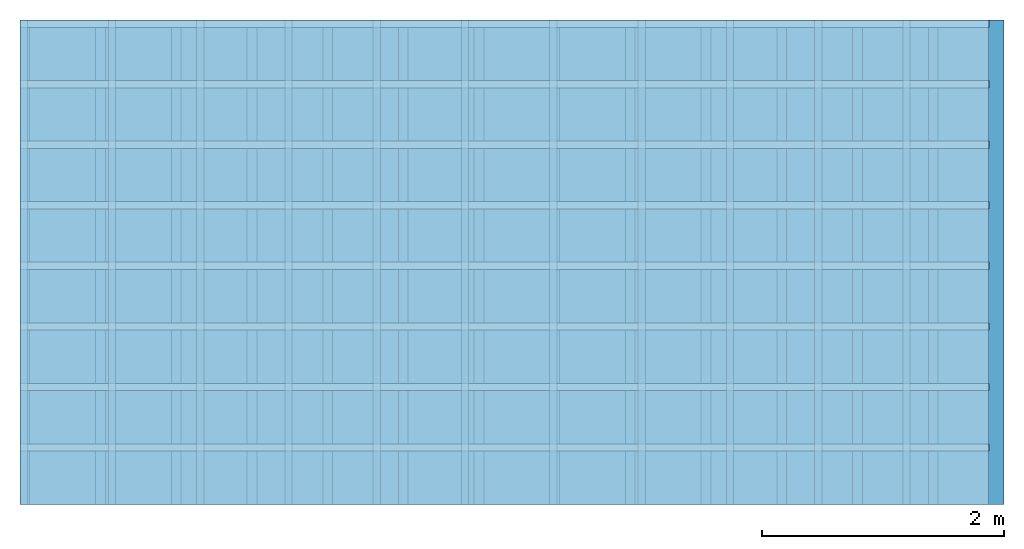
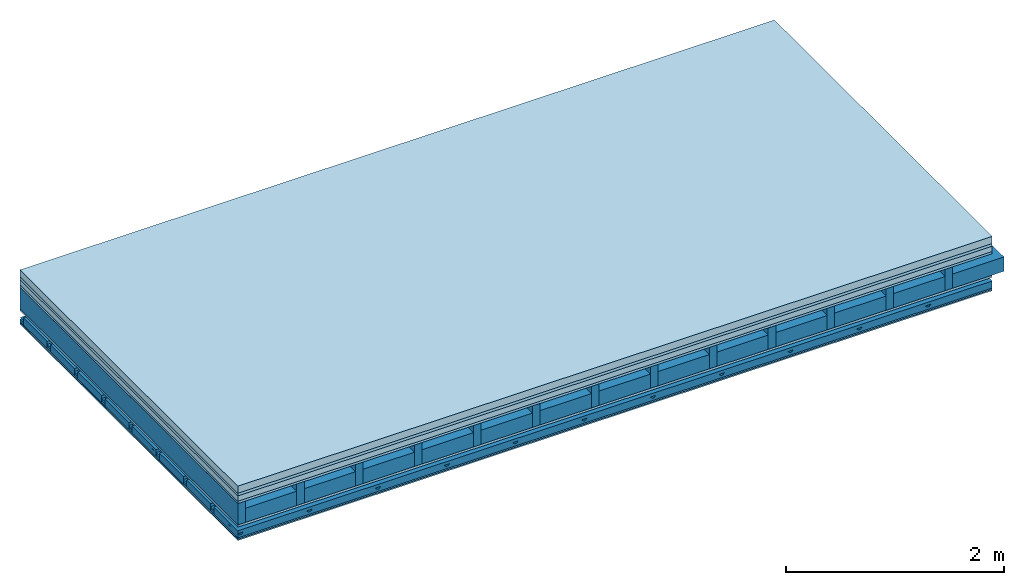
# One storey: 7 plates, 5 members, 1 element without a shape of its own.
"""IFC4 building model written with IfcOpenShell, lengths in metres."""

from ifc_helpers import new_model, si_unit, derived_unit, direction, frame, frame_2d, origin, origin_with_axes, place, context, project, spatial, polyline, rectangle, outline, extrude, material, layer, layer_set, type_object, element, aggregate, save


model = new_model("IFC4")

# Units and contexts
plan_context = context("Plan", 3, precision=1e-05, world=origin(), true_north=direction((0.0, 1.0)))
model_context = context("Model", 3, precision=1e-05, world=origin(), true_north=direction((0.0, 1.0)))
ifc_project = project(units=[si_unit("LENGTHUNIT", "METRE"), derived_unit("SOUNDPRESSUREUNIT", [(si_unit("PRESSUREUNIT", "PASCAL", prefix="MICRO"), 0)]), si_unit("ENERGYUNIT", "JOULE", prefix="MEGA"), si_unit("MASSUNIT", "GRAM", prefix="KILO"), derived_unit("THERMALTRANSMITTANCEUNIT", [(si_unit("POWERUNIT", "WATT"), 1), (si_unit("AREAUNIT", "SQUARE_METRE"), -1), (si_unit("THERMODYNAMICTEMPERATUREUNIT", "KELVIN"), -1)]), derived_unit("AREADENSITYUNIT", [(si_unit("MASSUNIT", "GRAM", prefix="KILO"), 1), (si_unit("AREAUNIT", "SQUARE_METRE"), -1)]), derived_unit("USERDEFINED", [(si_unit("ENERGYUNIT", "JOULE", prefix="MEGA"), 1), (si_unit("AREAUNIT", "SQUARE_METRE"), -1)])], contexts=[plan_context, model_context])

# Site, building, storey
site = spatial("IfcSite", under=ifc_project)
building_placement = place(None, origin())
building = spatial("IfcBuilding", under=site, at=building_placement)
storey_placement = place(building_placement, origin())
storey = spatial("IfcBuildingStorey", under=building, at=storey_placement)

# Slab, members, plates
ifc_material_1 = material(Name="Cement screed", Category="04.006")
ifc_layer_1 = layer(ifc_material_1, 0.08, Name="On-material")
ifc_material_2 = material()
ifc_layer_2 = layer(ifc_material_2, 0.03, Name="Impact sound insulation")
ifc_material_3 = material(Name="Cement panels, glued on sub-floor", Category="02.007")
ifc_layer_3 = layer(ifc_material_3, 0.06, Name="on Supporting structure")
ifc_material_4 = material(Category="07.001")
ifc_layer_4 = layer(ifc_material_4, 0.025, Name="Sub-floor")
ifc_material_5 = material(Name="Rigid, of the art")
ifc_layer_5 = layer(ifc_material_5, 0.0, Name="Bond")
ifc_layer_6 = layer(None, 0.24, Name="Supporting structure")
ifc_layer_7 = layer(ifc_material_5, 0.0, Name="Bond")
ifc_layer_8 = layer(ifc_material_4, 0.025, Name="Lower layer 1")
ifc_layer_9 = layer(None, 0.093, Name="Coupling")
ifc_layer_10 = layer(None, 0.027, Name="Battens / profiles")
ifc_material_6 = material(Category="03.007")
ifc_layer_11 = layer(ifc_material_6, 0.015, Name="Ceiling covering 1st layer")
ifc_layer_12 = layer(ifc_material_6, 0.015, Name="Ceiling covering layer 2")
ifc_material_7 = material(Name="Glued joints")
ifc_layer_13 = layer(ifc_material_7, 0.0, Name="Surface / treatment")
ifc_layer_set = layer_set([ifc_layer_1, ifc_layer_2, ifc_layer_3, ifc_layer_4, ifc_layer_5, ifc_layer_6, ifc_layer_7, ifc_layer_8, ifc_layer_9, ifc_layer_10, ifc_layer_11, ifc_layer_12, ifc_layer_13])
slab_type = type_object("IfcSlabType", Name="A0518", PredefinedType="NOTDEFINED", material=ifc_layer_set)
slab_placement = place(None, frame((0.0, 0.0, 0.0), z_axis=(0.0, 0.0, -1.0), x_axis=(1.0, 0.0, 0.0)))
slab = element("IfcSlab", 1, at=slab_placement, inside=storey, type_object=slab_type, material=ifc_layer_set, Name="Slab #1")
ifc_material_8 = material()
member_1_placement = place(slab_placement, origin())
member_1 = element("IfcMember", 2, at=member_1_placement, material=ifc_material_8, Name="Supporting structure", context=plan_context, shape_type="SweptSolid", body=[
    extrude(rectangle(XDim=0.08, YDim=0.24, at=frame_2d((0.04, 0.12), x_axis=(1.0, 0.0))), frame((0.0, 4.0, 0.195), z_axis=(0.0, -1.0, 0.0), x_axis=(1.0, 0.0, 0.0)), (0.0, 0.0, 1.0), 4.0),
    extrude(rectangle(XDim=0.08, YDim=0.24, at=frame_2d((0.04, 0.12), x_axis=(1.0, 0.0))), frame((0.625, 4.0, 0.195), z_axis=(0.0, -1.0, 0.0), x_axis=(1.0, 0.0, 0.0)), (0.0, 0.0, 1.0), 4.0),
    extrude(rectangle(XDim=0.08, YDim=0.24, at=frame_2d((0.04, 0.12), x_axis=(1.0, 0.0))), frame((1.25, 4.0, 0.195), z_axis=(0.0, -1.0, 0.0), x_axis=(1.0, 0.0, 0.0)), (0.0, 0.0, 1.0), 4.0),
    extrude(rectangle(XDim=0.08, YDim=0.24, at=frame_2d((0.04, 0.12), x_axis=(1.0, 0.0))), frame((1.875, 4.0, 0.195), z_axis=(0.0, -1.0, 0.0), x_axis=(1.0, 0.0, 0.0)), (0.0, 0.0, 1.0), 4.0),
    extrude(rectangle(XDim=0.08, YDim=0.24, at=frame_2d((0.04, 0.12), x_axis=(1.0, 0.0))), frame((2.5, 4.0, 0.195), z_axis=(0.0, -1.0, 0.0), x_axis=(1.0, 0.0, 0.0)), (0.0, 0.0, 1.0), 4.0),
    extrude(rectangle(XDim=0.08, YDim=0.24, at=frame_2d((0.04, 0.12), x_axis=(1.0, 0.0))), frame((3.125, 4.0, 0.195), z_axis=(0.0, -1.0, 0.0), x_axis=(1.0, 0.0, 0.0)), (0.0, 0.0, 1.0), 4.0),
    extrude(rectangle(XDim=0.08, YDim=0.24, at=frame_2d((0.04, 0.12), x_axis=(1.0, 0.0))), frame((3.75, 4.0, 0.195), z_axis=(0.0, -1.0, 0.0), x_axis=(1.0, 0.0, 0.0)), (0.0, 0.0, 1.0), 4.0),
    extrude(rectangle(XDim=0.08, YDim=0.24, at=frame_2d((0.04, 0.12), x_axis=(1.0, 0.0))), frame((4.375, 4.0, 0.195), z_axis=(0.0, -1.0, 0.0), x_axis=(1.0, 0.0, 0.0)), (0.0, 0.0, 1.0), 4.0),
    extrude(rectangle(XDim=0.08, YDim=0.24, at=frame_2d((0.04, 0.12), x_axis=(1.0, 0.0))), frame((5.0, 4.0, 0.195), z_axis=(0.0, -1.0, 0.0), x_axis=(1.0, 0.0, 0.0)), (0.0, 0.0, 1.0), 4.0),
    extrude(rectangle(XDim=0.08, YDim=0.24, at=frame_2d((0.04, 0.12), x_axis=(1.0, 0.0))), frame((5.625, 4.0, 0.195), z_axis=(0.0, -1.0, 0.0), x_axis=(1.0, 0.0, 0.0)), (0.0, 0.0, 1.0), 4.0),
    extrude(rectangle(XDim=0.08, YDim=0.24, at=frame_2d((0.04, 0.12), x_axis=(1.0, 0.0))), frame((6.25, 4.0, 0.195), z_axis=(0.0, -1.0, 0.0), x_axis=(1.0, 0.0, 0.0)), (0.0, 0.0, 1.0), 4.0),
    extrude(rectangle(XDim=0.08, YDim=0.24, at=frame_2d((0.04, 0.12), x_axis=(1.0, 0.0))), frame((6.875, 4.0, 0.195), z_axis=(0.0, -1.0, 0.0), x_axis=(1.0, 0.0, 0.0)), (0.0, 0.0, 1.0), 4.0),
    extrude(rectangle(XDim=0.08, YDim=0.24, at=frame_2d((0.04, 0.12), x_axis=(1.0, 0.0))), frame((7.5, 4.0, 0.195), z_axis=(0.0, -1.0, 0.0), x_axis=(1.0, 0.0, 0.0)), (0.0, 0.0, 1.0), 4.0),
])
ifc_material_9 = material()
member_2_placement = place(slab_placement, origin())
member_2 = element("IfcMember", 3, at=member_2_placement, material=ifc_material_9, Name="Cavity", context=plan_context, shape_type="SweptSolid", body=[
    extrude(rectangle(XDim=0.545, YDim=0.16, at=frame_2d((0.2725, 0.08), x_axis=(1.0, 0.0))), frame((0.08, 4.0, 0.275), z_axis=(0.0, -1.0, 0.0), x_axis=(1.0, 0.0, 0.0)), (0.0, 0.0, 1.0), 4.0),
    extrude(rectangle(XDim=0.545, YDim=0.16, at=frame_2d((0.2725, 0.08), x_axis=(1.0, 0.0))), frame((0.705, 4.0, 0.275), z_axis=(0.0, -1.0, 0.0), x_axis=(1.0, 0.0, 0.0)), (0.0, 0.0, 1.0), 4.0),
    extrude(rectangle(XDim=0.545, YDim=0.16, at=frame_2d((0.2725, 0.08), x_axis=(1.0, 0.0))), frame((1.33, 4.0, 0.275), z_axis=(0.0, -1.0, 0.0), x_axis=(1.0, 0.0, 0.0)), (0.0, 0.0, 1.0), 4.0),
    extrude(rectangle(XDim=0.545, YDim=0.16, at=frame_2d((0.2725, 0.08), x_axis=(1.0, 0.0))), frame((1.955, 4.0, 0.275), z_axis=(0.0, -1.0, 0.0), x_axis=(1.0, 0.0, 0.0)), (0.0, 0.0, 1.0), 4.0),
    extrude(rectangle(XDim=0.545, YDim=0.16, at=frame_2d((0.2725, 0.08), x_axis=(1.0, 0.0))), frame((2.58, 4.0, 0.275), z_axis=(0.0, -1.0, 0.0), x_axis=(1.0, 0.0, 0.0)), (0.0, 0.0, 1.0), 4.0),
    extrude(rectangle(XDim=0.545, YDim=0.16, at=frame_2d((0.2725, 0.08), x_axis=(1.0, 0.0))), frame((3.205, 4.0, 0.275), z_axis=(0.0, -1.0, 0.0), x_axis=(1.0, 0.0, 0.0)), (0.0, 0.0, 1.0), 4.0),
    extrude(rectangle(XDim=0.545, YDim=0.16, at=frame_2d((0.2725, 0.08), x_axis=(1.0, 0.0))), frame((3.83, 4.0, 0.275), z_axis=(0.0, -1.0, 0.0), x_axis=(1.0, 0.0, 0.0)), (0.0, 0.0, 1.0), 4.0),
    extrude(rectangle(XDim=0.545, YDim=0.16, at=frame_2d((0.2725, 0.08), x_axis=(1.0, 0.0))), frame((4.455, 4.0, 0.275), z_axis=(0.0, -1.0, 0.0), x_axis=(1.0, 0.0, 0.0)), (0.0, 0.0, 1.0), 4.0),
    extrude(rectangle(XDim=0.545, YDim=0.16, at=frame_2d((0.2725, 0.08), x_axis=(1.0, 0.0))), frame((5.08, 4.0, 0.275), z_axis=(0.0, -1.0, 0.0), x_axis=(1.0, 0.0, 0.0)), (0.0, 0.0, 1.0), 4.0),
    extrude(rectangle(XDim=0.545, YDim=0.16, at=frame_2d((0.2725, 0.08), x_axis=(1.0, 0.0))), frame((5.705, 4.0, 0.275), z_axis=(0.0, -1.0, 0.0), x_axis=(1.0, 0.0, 0.0)), (0.0, 0.0, 1.0), 4.0),
    extrude(rectangle(XDim=0.545, YDim=0.16, at=frame_2d((0.2725, 0.08), x_axis=(1.0, 0.0))), frame((6.33, 4.0, 0.275), z_axis=(0.0, -1.0, 0.0), x_axis=(1.0, 0.0, 0.0)), (0.0, 0.0, 1.0), 4.0),
    extrude(rectangle(XDim=0.545, YDim=0.16, at=frame_2d((0.2725, 0.08), x_axis=(1.0, 0.0))), frame((6.955, 4.0, 0.275), z_axis=(0.0, -1.0, 0.0), x_axis=(1.0, 0.0, 0.0)), (0.0, 0.0, 1.0), 4.0),
    extrude(rectangle(XDim=0.545, YDim=0.16, at=frame_2d((0.2725, 0.08), x_axis=(1.0, 0.0))), frame((7.58, 4.0, 0.275), z_axis=(0.0, -1.0, 0.0), x_axis=(1.0, 0.0, 0.0)), (0.0, 0.0, 1.0), 4.0),
])
ifc_material_10 = material()
member_3_placement = place(slab_placement, origin())
member_3 = element("IfcMember", 4, at=member_3_placement, material=ifc_material_10, Name="Coupling", context=plan_context, shape_type="SweptSolid", body=[
    extrude(outline(polyline([(0.0, 0.0), (0.06, 0.0), (0.04, 0.02), (0.02, 0.02), (0.0, 0.0)])), frame((0.0, 4.0, 0.533), z_axis=(0.0, -1.0, 0.0), x_axis=(1.0, 0.0, 0.0)), (0.0, 0.0, 1.0), 4.0),
    extrude(outline(polyline([(0.0, 0.0), (0.06, 0.0), (0.04, 0.02), (0.02, 0.02), (0.0, 0.0)])), frame((0.729, 4.0, 0.533), z_axis=(0.0, -1.0, 0.0), x_axis=(1.0, 0.0, 0.0)), (0.0, 0.0, 1.0), 4.0),
    extrude(outline(polyline([(0.0, 0.0), (0.06, 0.0), (0.04, 0.02), (0.02, 0.02), (0.0, 0.0)])), frame((1.458, 4.0, 0.533), z_axis=(0.0, -1.0, 0.0), x_axis=(1.0, 0.0, 0.0)), (0.0, 0.0, 1.0), 4.0),
    extrude(outline(polyline([(0.0, 0.0), (0.06, 0.0), (0.04, 0.02), (0.02, 0.02), (0.0, 0.0)])), frame((2.187, 4.0, 0.533), z_axis=(0.0, -1.0, 0.0), x_axis=(1.0, 0.0, 0.0)), (0.0, 0.0, 1.0), 4.0),
    extrude(outline(polyline([(0.0, 0.0), (0.06, 0.0), (0.04, 0.02), (0.02, 0.02), (0.0, 0.0)])), frame((2.916, 4.0, 0.533), z_axis=(0.0, -1.0, 0.0), x_axis=(1.0, 0.0, 0.0)), (0.0, 0.0, 1.0), 4.0),
    extrude(outline(polyline([(0.0, 0.0), (0.06, 0.0), (0.04, 0.02), (0.02, 0.02), (0.0, 0.0)])), frame((3.645, 4.0, 0.533), z_axis=(0.0, -1.0, 0.0), x_axis=(1.0, 0.0, 0.0)), (0.0, 0.0, 1.0), 4.0),
    extrude(outline(polyline([(0.0, 0.0), (0.06, 0.0), (0.04, 0.02), (0.02, 0.02), (0.0, 0.0)])), frame((4.374, 4.0, 0.533), z_axis=(0.0, -1.0, 0.0), x_axis=(1.0, 0.0, 0.0)), (0.0, 0.0, 1.0), 4.0),
    extrude(outline(polyline([(0.0, 0.0), (0.06, 0.0), (0.04, 0.02), (0.02, 0.02), (0.0, 0.0)])), frame((5.103, 4.0, 0.533), z_axis=(0.0, -1.0, 0.0), x_axis=(1.0, 0.0, 0.0)), (0.0, 0.0, 1.0), 4.0),
    extrude(outline(polyline([(0.0, 0.0), (0.06, 0.0), (0.04, 0.02), (0.02, 0.02), (0.0, 0.0)])), frame((5.832, 4.0, 0.533), z_axis=(0.0, -1.0, 0.0), x_axis=(1.0, 0.0, 0.0)), (0.0, 0.0, 1.0), 4.0),
    extrude(outline(polyline([(0.0, 0.0), (0.06, 0.0), (0.04, 0.02), (0.02, 0.02), (0.0, 0.0)])), frame((6.561, 4.0, 0.533), z_axis=(0.0, -1.0, 0.0), x_axis=(1.0, 0.0, 0.0)), (0.0, 0.0, 1.0), 4.0),
    extrude(outline(polyline([(0.0, 0.0), (0.06, 0.0), (0.04, 0.02), (0.02, 0.02), (0.0, 0.0)])), frame((7.29, 4.0, 0.533), z_axis=(0.0, -1.0, 0.0), x_axis=(1.0, 0.0, 0.0)), (0.0, 0.0, 1.0), 4.0),
])
ifc_material_11 = material()
member_4_placement = place(slab_placement, origin())
member_4 = element("IfcMember", 5, at=member_4_placement, material=ifc_material_11, Name="Battens / profiles", context=plan_context, shape_type="SweptSolid", body=[
    extrude(rectangle(XDim=0.06, YDim=0.027, at=frame_2d((0.03, 0.0135), x_axis=(1.0, 0.0))), frame((0.0, 0.0, 0.553), z_axis=(1.0, 0.0, 0.0), x_axis=(0.0, 1.0, 0.0)), (0.0, 0.0, 1.0), 8.0),
    extrude(rectangle(XDim=0.06, YDim=0.027, at=frame_2d((0.03, 0.0135), x_axis=(1.0, 0.0))), frame((0.0, 0.5, 0.553), z_axis=(1.0, 0.0, 0.0), x_axis=(0.0, 1.0, 0.0)), (0.0, 0.0, 1.0), 8.0),
    extrude(rectangle(XDim=0.06, YDim=0.027, at=frame_2d((0.03, 0.0135), x_axis=(1.0, 0.0))), frame((0.0, 1.0, 0.553), z_axis=(1.0, 0.0, 0.0), x_axis=(0.0, 1.0, 0.0)), (0.0, 0.0, 1.0), 8.0),
    extrude(rectangle(XDim=0.06, YDim=0.027, at=frame_2d((0.03, 0.0135), x_axis=(1.0, 0.0))), frame((0.0, 1.5, 0.553), z_axis=(1.0, 0.0, 0.0), x_axis=(0.0, 1.0, 0.0)), (0.0, 0.0, 1.0), 8.0),
    extrude(rectangle(XDim=0.06, YDim=0.027, at=frame_2d((0.03, 0.0135), x_axis=(1.0, 0.0))), frame((0.0, 2.0, 0.553), z_axis=(1.0, 0.0, 0.0), x_axis=(0.0, 1.0, 0.0)), (0.0, 0.0, 1.0), 8.0),
    extrude(rectangle(XDim=0.06, YDim=0.027, at=frame_2d((0.03, 0.0135), x_axis=(1.0, 0.0))), frame((0.0, 2.5, 0.553), z_axis=(1.0, 0.0, 0.0), x_axis=(0.0, 1.0, 0.0)), (0.0, 0.0, 1.0), 8.0),
    extrude(rectangle(XDim=0.06, YDim=0.027, at=frame_2d((0.03, 0.0135), x_axis=(1.0, 0.0))), frame((0.0, 3.0, 0.553), z_axis=(1.0, 0.0, 0.0), x_axis=(0.0, 1.0, 0.0)), (0.0, 0.0, 1.0), 8.0),
    extrude(rectangle(XDim=0.06, YDim=0.027, at=frame_2d((0.03, 0.0135), x_axis=(1.0, 0.0))), frame((0.0, 3.5, 0.553), z_axis=(1.0, 0.0, 0.0), x_axis=(0.0, 1.0, 0.0)), (0.0, 0.0, 1.0), 8.0),
])
member_5_placement = place(slab_placement, origin())
member_5 = element("IfcMember", 6, at=member_5_placement, material=ifc_material_9, Name="Cavity", context=plan_context, shape_type="SweptSolid", body=[
    extrude(rectangle(XDim=0.44, YDim=0.08, at=frame_2d((0.22, 0.04), x_axis=(1.0, 0.0))), frame((0.0, 0.06, 0.5), z_axis=(1.0, 0.0, 0.0), x_axis=(0.0, 1.0, 0.0)), (0.0, 0.0, 1.0), 8.0),
    extrude(rectangle(XDim=0.44, YDim=0.08, at=frame_2d((0.22, 0.04), x_axis=(1.0, 0.0))), frame((0.0, 0.56, 0.5), z_axis=(1.0, 0.0, 0.0), x_axis=(0.0, 1.0, 0.0)), (0.0, 0.0, 1.0), 8.0),
    extrude(rectangle(XDim=0.44, YDim=0.08, at=frame_2d((0.22, 0.04), x_axis=(1.0, 0.0))), frame((0.0, 1.06, 0.5), z_axis=(1.0, 0.0, 0.0), x_axis=(0.0, 1.0, 0.0)), (0.0, 0.0, 1.0), 8.0),
    extrude(rectangle(XDim=0.44, YDim=0.08, at=frame_2d((0.22, 0.04), x_axis=(1.0, 0.0))), frame((0.0, 1.56, 0.5), z_axis=(1.0, 0.0, 0.0), x_axis=(0.0, 1.0, 0.0)), (0.0, 0.0, 1.0), 8.0),
    extrude(rectangle(XDim=0.44, YDim=0.08, at=frame_2d((0.22, 0.04), x_axis=(1.0, 0.0))), frame((0.0, 2.06, 0.5), z_axis=(1.0, 0.0, 0.0), x_axis=(0.0, 1.0, 0.0)), (0.0, 0.0, 1.0), 8.0),
    extrude(rectangle(XDim=0.44, YDim=0.08, at=frame_2d((0.22, 0.04), x_axis=(1.0, 0.0))), frame((0.0, 2.56, 0.5), z_axis=(1.0, 0.0, 0.0), x_axis=(0.0, 1.0, 0.0)), (0.0, 0.0, 1.0), 8.0),
    extrude(rectangle(XDim=0.44, YDim=0.08, at=frame_2d((0.22, 0.04), x_axis=(1.0, 0.0))), frame((0.0, 3.06, 0.5), z_axis=(1.0, 0.0, 0.0), x_axis=(0.0, 1.0, 0.0)), (0.0, 0.0, 1.0), 8.0),
    extrude(rectangle(XDim=0.44, YDim=0.08, at=frame_2d((0.22, 0.04), x_axis=(1.0, 0.0))), frame((0.0, 3.56, 0.5), z_axis=(1.0, 0.0, 0.0), x_axis=(0.0, 1.0, 0.0)), (0.0, 0.0, 1.0), 8.0),
])
plate_1_placement = place(slab_placement, origin())
plate_1 = element("IfcPlate", 7, at=plate_1_placement, material=ifc_material_1, Name="On-material", context=plan_context, shape_type="SweptSolid", body=[
    extrude(rectangle(XDim=8.0, YDim=4.0, at=frame_2d((4.0, 2.0), x_axis=(1.0, 0.0))), origin_with_axes(), (0.0, 0.0, 1.0), 0.08),
])
plate_2_placement = place(slab_placement, origin())
plate_2 = element("IfcPlate", 8, at=plate_2_placement, material=ifc_material_2, Name="Impact sound insulation", context=plan_context, shape_type="SweptSolid", body=[
    extrude(rectangle(XDim=8.0, YDim=4.0, at=frame_2d((4.0, 2.0), x_axis=(1.0, 0.0))), frame((0.0, 0.0, 0.08), z_axis=(0.0, 0.0, 1.0), x_axis=(1.0, 0.0, 0.0)), (0.0, 0.0, 1.0), 0.03),
])
plate_3_placement = place(slab_placement, origin())
plate_3 = element("IfcPlate", 9, at=plate_3_placement, material=ifc_material_3, Name="on Supporting structure", context=plan_context, shape_type="SweptSolid", body=[
    extrude(rectangle(XDim=8.0, YDim=4.0, at=frame_2d((4.0, 2.0), x_axis=(1.0, 0.0))), frame((0.0, 0.0, 0.11), z_axis=(0.0, 0.0, 1.0), x_axis=(1.0, 0.0, 0.0)), (0.0, 0.0, 1.0), 0.06),
])
plate_4_placement = place(slab_placement, origin())
plate_4 = element("IfcPlate", 10, at=plate_4_placement, material=ifc_material_4, Name="Sub-floor", context=plan_context, shape_type="SweptSolid", body=[
    extrude(rectangle(XDim=8.0, YDim=4.0, at=frame_2d((4.0, 2.0), x_axis=(1.0, 0.0))), frame((0.0, 0.0, 0.17), z_axis=(0.0, 0.0, 1.0), x_axis=(1.0, 0.0, 0.0)), (0.0, 0.0, 1.0), 0.025),
])
plate_5_placement = place(slab_placement, origin())
plate_5 = element("IfcPlate", 11, at=plate_5_placement, material=ifc_material_4, Name="Lower layer 1", context=plan_context, shape_type="SweptSolid", body=[
    extrude(rectangle(XDim=8.0, YDim=4.0, at=frame_2d((4.0, 2.0), x_axis=(1.0, 0.0))), frame((0.0, 0.0, 0.435), z_axis=(0.0, 0.0, 1.0), x_axis=(1.0, 0.0, 0.0)), (0.0, 0.0, 1.0), 0.025),
])
plate_6_placement = place(slab_placement, origin())
plate_6 = element("IfcPlate", 12, at=plate_6_placement, material=ifc_material_6, Name="Ceiling covering 1st layer", context=plan_context, shape_type="SweptSolid", body=[
    extrude(rectangle(XDim=8.0, YDim=4.0, at=frame_2d((4.0, 2.0), x_axis=(1.0, 0.0))), frame((0.0, 0.0, 0.58), z_axis=(0.0, 0.0, 1.0), x_axis=(1.0, 0.0, 0.0)), (0.0, 0.0, 1.0), 0.015),
])
plate_7_placement = place(slab_placement, origin())
plate_7 = element("IfcPlate", 13, at=plate_7_placement, material=ifc_material_6, Name="Ceiling covering layer 2", context=plan_context, shape_type="SweptSolid", body=[
    extrude(rectangle(XDim=8.0, YDim=4.0, at=frame_2d((4.0, 2.0), x_axis=(1.0, 0.0))), frame((0.0, 0.0, 0.595), z_axis=(0.0, 0.0, 1.0), x_axis=(1.0, 0.0, 0.0)), (0.0, 0.0, 1.0), 0.015),
])
aggregate(slab, [plate_1, plate_2, plate_3, plate_4, member_1, member_2, plate_5, member_3, member_4, member_5, plate_6, plate_7])

save(model, "model.ifc")
